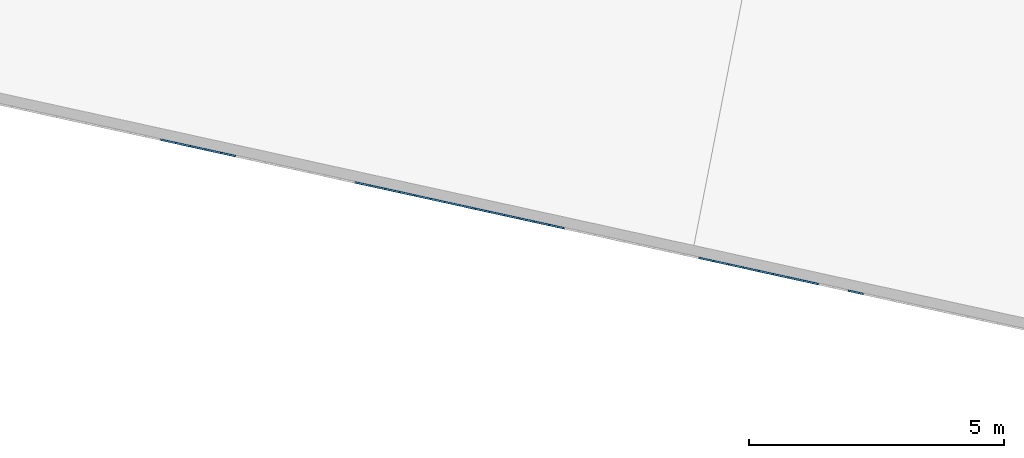
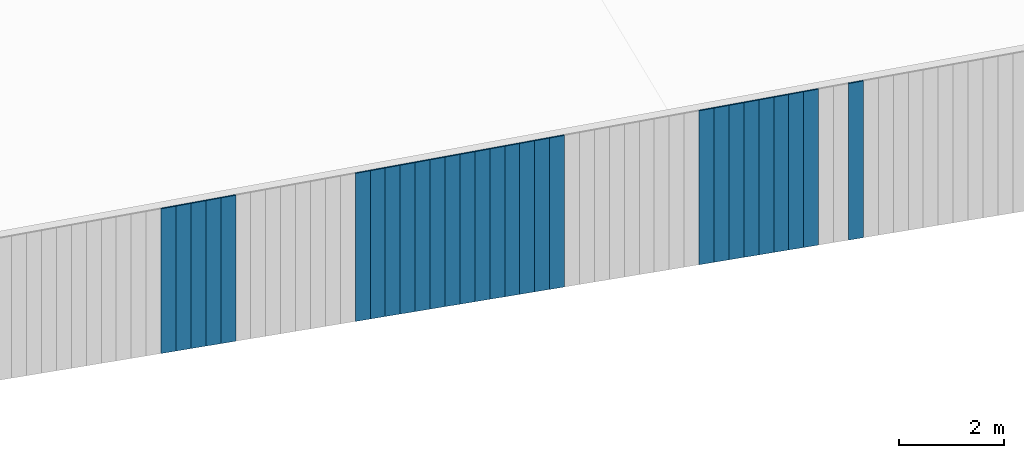
# One storey, part 3 of 18: 28 plates, 1 element without a shape of its own.
"""IFC2X3 building model written with IfcOpenShell, lengths in centimetres."""

from ifc_helpers import new_model, entity, si_unit, converted_unit, derived_unit, direction, frame, origin, place, context, subcontext, project, spatial, polyline, outline, extrude, source, transform, mapped, material, layer, layer_set, layer_usage, type_object, type_shapes, element, aggregate, save


model = new_model("IFC2X3")

# Units and contexts
model_context = context("Model", 3, precision=0.001, world=origin(), true_north=direction((6.12303176911189e-17, 1.0)))
body_context = subcontext(model_context, "Body", "Model", "MODEL_VIEW")
ifc_project = project(units=[si_unit("LENGTHUNIT", "METRE", prefix="CENTI"), si_unit("AREAUNIT", "SQUARE_METRE"), si_unit("VOLUMEUNIT", "CUBIC_METRE"), converted_unit("PLANEANGLEUNIT", "DEGREE", entity("IfcRatioMeasure", 0.0174532925199433), si_unit("PLANEANGLEUNIT", "RADIAN"), dimensions=[0, 0, 0, 0, 0, 0, 0]), si_unit("MASSUNIT", "GRAM", prefix="KILO"), derived_unit("MASSDENSITYUNIT", [(si_unit("MASSUNIT", "GRAM", prefix="KILO"), 1), (si_unit("LENGTHUNIT", "METRE"), -3)]), si_unit("TIMEUNIT", "SECOND"), si_unit("FREQUENCYUNIT", "HERTZ"), si_unit("THERMODYNAMICTEMPERATUREUNIT", "DEGREE_CELSIUS"), derived_unit("THERMALTRANSMITTANCEUNIT", [(si_unit("MASSUNIT", "GRAM", prefix="KILO"), 1), (si_unit("THERMODYNAMICTEMPERATUREUNIT", "KELVIN"), -1), (si_unit("TIMEUNIT", "SECOND"), -3)]), derived_unit("VOLUMETRICFLOWRATEUNIT", [(si_unit("LENGTHUNIT", "METRE"), 3), (si_unit("TIMEUNIT", "SECOND"), -1)]), si_unit("ELECTRICCURRENTUNIT", "AMPERE"), si_unit("ELECTRICVOLTAGEUNIT", "VOLT"), si_unit("POWERUNIT", "WATT"), si_unit("FORCEUNIT", "NEWTON", prefix="KILO"), si_unit("ILLUMINANCEUNIT", "LUX"), si_unit("LUMINOUSFLUXUNIT", "LUMEN"), si_unit("LUMINOUSINTENSITYUNIT", "CANDELA"), derived_unit("USERDEFINED", [(si_unit("MASSUNIT", "GRAM", prefix="KILO"), -1), (si_unit("LENGTHUNIT", "METRE"), -2), (si_unit("TIMEUNIT", "SECOND"), 3), (si_unit("LUMINOUSFLUXUNIT", "LUMEN"), 1)]), derived_unit("LINEARVELOCITYUNIT", [(si_unit("LENGTHUNIT", "METRE"), 1), (si_unit("TIMEUNIT", "SECOND"), -1)]), si_unit("PRESSUREUNIT", "PASCAL"), derived_unit("USERDEFINED", [(si_unit("LENGTHUNIT", "METRE"), -2), (si_unit("MASSUNIT", "GRAM", prefix="KILO"), 1), (si_unit("TIMEUNIT", "SECOND"), -2)])], contexts=[model_context])

# Site, building, storey
site_placement = place(None, origin())
site = spatial("IfcSite", under=ifc_project, at=site_placement, CompositionType="ELEMENT")
building_placement = place(site_placement, origin())
building = spatial("IfcBuilding", under=site, at=building_placement, CompositionType="ELEMENT")
storey_placement = place(building_placement, frame((0.0, 0.0, 1422.0)))
storey = spatial("IfcBuildingStorey", under=building, at=storey_placement, CompositionType="ELEMENT", Elevation=1422.0)

# Curtain wall, plates
curtain_wall_type = type_object("IfcCurtainWallType", PredefinedType="NOTDEFINED")
curtain_wall_placement = place(storey_placement, frame((0.0, 0.0, -1422.0)))
curtain_wall = element("IfcCurtainWall", 1, at=curtain_wall_placement, inside=storey, type_object=curtain_wall_type)
ifc_material = material()
ifc_layer = layer(ifc_material, 3.0)
ifc_layer_set = layer_set([ifc_layer])
ifc_layer_usage_1 = layer_usage(ifc_layer_set, "AXIS3", "POSITIVE", 0.0492125984251968)
plate_type_1 = type_object("IfcPlateType", Name="Panneau plein ST", PredefinedType="CURTAIN_PANEL", material=ifc_layer_set)
shared_shape_1 = source(origin(), body_context, "Body", "SweptSolid", [
    extrude(outline(polyline([(-183.212415380879, -15.0), (182.912850252961, -15.0), (182.912850252961, 15.0), (-182.613285125043, 15.0), (-183.212415380879, -15.0)])), frame((0.0, 0.0, 183.212415380879), z_axis=(0.0, 1.0, 0.0), x_axis=(0.0, 0.0, 1.0)), (0.0, 0.0, 1.0), 3.0),
])
type_shapes(plate_type_1, [shared_shape_1])
plate_1_placement = place(curtain_wall_placement, frame((6807.38308458156, 477.823414082105, 1055.87473436616), z_axis=(0.0, 0.0, 1.0), x_axis=(-0.976731958442773, 0.214463706385357, 0.0)))
plate_1 = element("IfcPlate", 2, at=plate_1_placement, type_object=plate_type_1, material=ifc_layer_usage_1, ObjectType="Panneau plein ST", context=body_context, shape_type="MappedRepresentation", body=[
    mapped(shared_shape_1, transform((0.0, 0.0, 0.0), scale=1.0)),
])
ifc_layer_usage_2 = layer_usage(ifc_layer_set, "AXIS3", "POSITIVE", 0.0492125984251968)
plate_type_2 = type_object("IfcPlateType", Name="Panneau plein ST", PredefinedType="CURTAIN_PANEL", material=ifc_layer_set)
shared_shape_2 = source(origin(), body_context, "Body", "SweptSolid", [
    extrude(outline(polyline([(-182.313719997125, -15.0), (182.014154869207, -15.0), (182.014154869207, 15.0), (-181.714589741289, 15.0), (-182.313719997125, -15.0)])), frame((0.0, 0.0, 182.313719997125), z_axis=(0.0, 1.0, 0.0), x_axis=(0.0, 0.0, 1.0)), (0.0, 0.0, 1.0), 3.0),
])
type_shapes(plate_type_2, [shared_shape_2])
plate_2_placement = place(curtain_wall_placement, frame((6719.47720832171, 497.125147656787, 1057.67212513367), z_axis=(0.0, 0.0, 1.0), x_axis=(-0.976731958442773, 0.214463706385357, 0.0)))
plate_2 = element("IfcPlate", 3, at=plate_2_placement, type_object=plate_type_2, material=ifc_layer_usage_2, ObjectType="Panneau plein ST", context=body_context, shape_type="MappedRepresentation", body=[
    mapped(shared_shape_2, transform((0.0, 0.0, 0.0), scale=1.0)),
])
ifc_layer_usage_3 = layer_usage(ifc_layer_set, "AXIS3", "POSITIVE", 0.0492125984251968)
plate_type_3 = type_object("IfcPlateType", Name="Panneau plein ST", PredefinedType="CURTAIN_PANEL", material=ifc_layer_set)
shared_shape_3 = source(origin(), body_context, "Body", "SweptSolid", [
    extrude(outline(polyline([(-182.014154869207, -15.0), (181.714589741289, -15.0), (181.714589741289, 15.0), (-181.415024613371, 15.0), (-182.014154869207, -15.0)])), frame((0.0, 0.0, 182.014154869207), z_axis=(0.0, 1.0, 0.0), x_axis=(0.0, 0.0, 1.0)), (0.0, 0.0, 1.0), 3.0),
])
type_shapes(plate_type_3, [shared_shape_3])
plate_3_placement = place(curtain_wall_placement, frame((6690.17524956843, 503.559058848348, 1058.2712553895), z_axis=(0.0, 0.0, 1.0), x_axis=(-0.976731958442773, 0.214463706385357, 0.0)))
plate_3 = element("IfcPlate", 4, at=plate_3_placement, type_object=plate_type_3, material=ifc_layer_usage_3, ObjectType="Panneau plein ST", context=body_context, shape_type="MappedRepresentation", body=[
    mapped(shared_shape_3, transform((0.0, 0.0, 0.0), scale=1.0)),
])
ifc_layer_usage_4 = layer_usage(ifc_layer_set, "AXIS3", "POSITIVE", 0.0492125984251968)
plate_type_4 = type_object("IfcPlateType", Name="Panneau plein ST", PredefinedType="CURTAIN_PANEL", material=ifc_layer_set)
shared_shape_4 = source(origin(), body_context, "Body", "SweptSolid", [
    extrude(outline(polyline([(-181.714589741289, -15.0), (181.415024613371, -15.0), (181.415024613371, 15.0), (-181.115459485453, 15.0), (-181.714589741289, -15.0)])), frame((0.0, 0.0, 181.714589741289), z_axis=(0.0, 1.0, 0.0), x_axis=(0.0, 0.0, 1.0)), (0.0, 0.0, 1.0), 3.0),
])
type_shapes(plate_type_4, [shared_shape_4])
plate_4_placement = place(curtain_wall_placement, frame((6660.87329081514, 509.992970039909, 1058.87038564534), z_axis=(0.0, 0.0, 1.0), x_axis=(-0.976731958442773, 0.214463706385357, 0.0)))
plate_4 = element("IfcPlate", 5, at=plate_4_placement, type_object=plate_type_4, material=ifc_layer_usage_4, ObjectType="Panneau plein ST", context=body_context, shape_type="MappedRepresentation", body=[
    mapped(shared_shape_4, transform((0.0, 0.0, 0.0), scale=1.0)),
])
ifc_layer_usage_5 = layer_usage(ifc_layer_set, "AXIS3", "POSITIVE", 0.0492125984251968)
plate_type_5 = type_object("IfcPlateType", Name="Panneau plein ST", PredefinedType="CURTAIN_PANEL", material=ifc_layer_set)
shared_shape_5 = source(origin(), body_context, "Body", "SweptSolid", [
    extrude(outline(polyline([(-181.415024613371, -15.0), (181.115459485453, -15.0), (181.115459485453, 15.0), (-180.815894357535, 15.0), (-181.415024613371, -15.0)])), frame((0.0, 0.0, 181.415024613371), z_axis=(0.0, 1.0, 0.0), x_axis=(0.0, 0.0, 1.0)), (0.0, 0.0, 1.0), 3.0),
])
type_shapes(plate_type_5, [shared_shape_5])
plate_5_placement = place(curtain_wall_placement, frame((6631.57133206186, 516.42688123147, 1059.46951590118), z_axis=(0.0, 0.0, 1.0), x_axis=(-0.976731958442773, 0.214463706385357, 0.0)))
plate_5 = element("IfcPlate", 6, at=plate_5_placement, type_object=plate_type_5, material=ifc_layer_usage_5, ObjectType="Panneau plein ST", context=body_context, shape_type="MappedRepresentation", body=[
    mapped(shared_shape_5, transform((0.0, 0.0, 0.0), scale=1.0)),
])
ifc_layer_usage_6 = layer_usage(ifc_layer_set, "AXIS3", "POSITIVE", 0.0492125984251968)
plate_type_6 = type_object("IfcPlateType", Name="Panneau plein ST", PredefinedType="CURTAIN_PANEL", material=ifc_layer_set)
shared_shape_6 = source(origin(), body_context, "Body", "SweptSolid", [
    extrude(outline(polyline([(-181.115459485453, -15.0), (180.815894357535, -15.0), (180.815894357535, 15.0), (-180.516329229617, 15.0), (-181.115459485453, -15.0)])), frame((0.0, 0.0, 181.115459485453), z_axis=(0.0, 1.0, 0.0), x_axis=(0.0, 0.0, 1.0)), (0.0, 0.0, 1.0), 3.0),
])
type_shapes(plate_type_6, [shared_shape_6])
plate_6_placement = place(curtain_wall_placement, frame((6602.26937330857, 522.86079242303, 1060.06864615701), z_axis=(0.0, 0.0, 1.0), x_axis=(-0.976731958442773, 0.214463706385357, 0.0)))
plate_6 = element("IfcPlate", 7, at=plate_6_placement, type_object=plate_type_6, material=ifc_layer_usage_6, ObjectType="Panneau plein ST", context=body_context, shape_type="MappedRepresentation", body=[
    mapped(shared_shape_6, transform((0.0, 0.0, 0.0), scale=1.0)),
])
ifc_layer_usage_7 = layer_usage(ifc_layer_set, "AXIS3", "POSITIVE", 0.0492125984251968)
plate_type_7 = type_object("IfcPlateType", Name="Panneau plein ST", PredefinedType="CURTAIN_PANEL", material=ifc_layer_set)
shared_shape_7 = source(origin(), body_context, "Body", "SweptSolid", [
    extrude(outline(polyline([(-180.815894357535, -15.0), (180.516329229617, -15.0), (180.516329229617, 15.0), (-180.216764101699, 15.0), (-180.815894357535, -15.0)])), frame((0.0, 0.0, 180.815894357535), z_axis=(0.0, 1.0, 0.0), x_axis=(0.0, 0.0, 1.0)), (0.0, 0.0, 1.0), 3.0),
])
type_shapes(plate_type_7, [shared_shape_7])
plate_7_placement = place(curtain_wall_placement, frame((6572.96741455529, 529.294703614591, 1060.66777641285), z_axis=(0.0, 0.0, 1.0), x_axis=(-0.976731958442773, 0.214463706385357, 0.0)))
plate_7 = element("IfcPlate", 8, at=plate_7_placement, type_object=plate_type_7, material=ifc_layer_usage_7, ObjectType="Panneau plein ST", context=body_context, shape_type="MappedRepresentation", body=[
    mapped(shared_shape_7, transform((0.0, 0.0, 0.0), scale=1.0)),
])
ifc_layer_usage_8 = layer_usage(ifc_layer_set, "AXIS3", "POSITIVE", 0.0492125984251968)
plate_type_8 = type_object("IfcPlateType", Name="Panneau plein ST", PredefinedType="CURTAIN_PANEL", material=ifc_layer_set)
shared_shape_8 = source(origin(), body_context, "Body", "SweptSolid", [
    extrude(outline(polyline([(-180.516329229617, -15.0), (180.216764101699, -15.0), (180.216764101699, 15.0), (-179.917198973781, 15.0), (-180.516329229617, -15.0)])), frame((0.0, 0.0, 180.516329229617), z_axis=(0.0, 1.0, 0.0), x_axis=(0.0, 0.0, 1.0)), (0.0, 0.0, 1.0), 3.0),
])
type_shapes(plate_type_8, [shared_shape_8])
plate_8_placement = place(curtain_wall_placement, frame((6543.66545580201, 535.728614806151, 1061.26690666868), z_axis=(0.0, 0.0, 1.0), x_axis=(-0.976731958442773, 0.214463706385357, 0.0)))
plate_8 = element("IfcPlate", 9, at=plate_8_placement, type_object=plate_type_8, material=ifc_layer_usage_8, ObjectType="Panneau plein ST", context=body_context, shape_type="MappedRepresentation", body=[
    mapped(shared_shape_8, transform((0.0, 0.0, 0.0), scale=1.0)),
])
ifc_layer_usage_9 = layer_usage(ifc_layer_set, "AXIS3", "POSITIVE", 0.0492125984251968)
plate_type_9 = type_object("IfcPlateType", Name="Panneau plein ST", PredefinedType="CURTAIN_PANEL", material=ifc_layer_set)
shared_shape_9 = source(origin(), body_context, "Body", "SweptSolid", [
    extrude(outline(polyline([(-180.216764101699, -15.0), (179.917198973781, -15.0), (179.917198973781, 15.0), (-179.617633845863, 15.0), (-180.216764101699, -15.0)])), frame((0.0, 0.0, 180.216764101699), z_axis=(0.0, 1.0, 0.0), x_axis=(0.0, 0.0, 1.0)), (0.0, 0.0, 1.0), 3.0),
])
type_shapes(plate_type_9, [shared_shape_9])
plate_9_placement = place(curtain_wall_placement, frame((6514.36349704872, 542.162525997712, 1061.86603692452), z_axis=(0.0, 0.0, 1.0), x_axis=(-0.976731958442773, 0.214463706385357, 0.0)))
plate_9 = element("IfcPlate", 10, at=plate_9_placement, type_object=plate_type_9, material=ifc_layer_usage_9, ObjectType="Panneau plein ST", context=body_context, shape_type="MappedRepresentation", body=[
    mapped(shared_shape_9, transform((0.0, 0.0, 0.0), scale=1.0)),
])
ifc_layer_usage_10 = layer_usage(ifc_layer_set, "AXIS3", "POSITIVE", 0.0492125984251968)
plate_type_10 = type_object("IfcPlateType", Name="Panneau plein ST", PredefinedType="CURTAIN_PANEL", material=ifc_layer_set)
shared_shape_10 = source(origin(), body_context, "Body", "SweptSolid", [
    extrude(outline(polyline([(-177.221112822519, -15.0), (176.921547694601, -15.0), (176.921547694601, 15.0), (-176.621982566683, 15.0), (-177.221112822519, -15.0)])), frame((0.0, 0.0, 177.221112822519), z_axis=(0.0, 1.0, 0.0), x_axis=(0.0, 0.0, 1.0)), (0.0, 0.0, 1.0), 3.0),
])
type_shapes(plate_type_10, [shared_shape_10])
plate_10_placement = place(curtain_wall_placement, frame((6221.34390951589, 606.50163791332, 1067.85733948288), z_axis=(0.0, 0.0, 1.0), x_axis=(-0.976731958442773, 0.214463706385357, 0.0)))
plate_10 = element("IfcPlate", 11, at=plate_10_placement, type_object=plate_type_10, material=ifc_layer_usage_10, ObjectType="Panneau plein ST", context=body_context, shape_type="MappedRepresentation", body=[
    mapped(shared_shape_10, transform((0.0, 0.0, 0.0), scale=1.0)),
])
ifc_layer_usage_11 = layer_usage(ifc_layer_set, "AXIS3", "POSITIVE", 0.0492125984251968)
plate_type_11 = type_object("IfcPlateType", Name="Panneau plein ST", PredefinedType="CURTAIN_PANEL", material=ifc_layer_set)
shared_shape_11 = source(origin(), body_context, "Body", "SweptSolid", [
    extrude(outline(polyline([(-176.921547694601, -15.0), (176.621982566683, -15.0), (176.621982566683, 15.0), (-176.322417438765, 15.0), (-176.921547694601, -15.0)])), frame((0.0, 0.0, 176.921547694601), z_axis=(0.0, 1.0, 0.0), x_axis=(0.0, 0.0, 1.0)), (0.0, 0.0, 1.0), 3.0),
])
type_shapes(plate_type_11, [shared_shape_11])
plate_11_placement = place(curtain_wall_placement, frame((6192.04195076261, 612.93554910488, 1068.45646973872), z_axis=(0.0, 0.0, 1.0), x_axis=(-0.976731958442773, 0.214463706385357, 0.0)))
plate_11 = element("IfcPlate", 12, at=plate_11_placement, type_object=plate_type_11, material=ifc_layer_usage_11, ObjectType="Panneau plein ST", context=body_context, shape_type="MappedRepresentation", body=[
    mapped(shared_shape_11, transform((0.0, 0.0, 0.0), scale=1.0)),
])
ifc_layer_usage_12 = layer_usage(ifc_layer_set, "AXIS3", "POSITIVE", 0.0492125984251968)
plate_type_12 = type_object("IfcPlateType", Name="Panneau plein ST", PredefinedType="CURTAIN_PANEL", material=ifc_layer_set)
shared_shape_12 = source(origin(), body_context, "Body", "SweptSolid", [
    extrude(outline(polyline([(-176.621982566683, -15.0), (176.322417438765, -15.0), (176.322417438765, 15.0), (-176.022852310847, 15.0), (-176.621982566683, -15.0)])), frame((0.0, 0.0, 176.621982566683), z_axis=(0.0, 1.0, 0.0), x_axis=(0.0, 0.0, 1.0)), (0.0, 0.0, 1.0), 3.0),
])
type_shapes(plate_type_12, [shared_shape_12])
plate_12_placement = place(curtain_wall_placement, frame((6162.73999200932, 619.369460296441, 1069.05559999455), z_axis=(0.0, 0.0, 1.0), x_axis=(-0.976731958442773, 0.214463706385357, 0.0)))
plate_12 = element("IfcPlate", 13, at=plate_12_placement, type_object=plate_type_12, material=ifc_layer_usage_12, ObjectType="Panneau plein ST", context=body_context, shape_type="MappedRepresentation", body=[
    mapped(shared_shape_12, transform((0.0, 0.0, 0.0), scale=1.0)),
])
ifc_layer_usage_13 = layer_usage(ifc_layer_set, "AXIS3", "POSITIVE", 0.0492125984251968)
plate_type_13 = type_object("IfcPlateType", Name="Panneau plein ST", PredefinedType="CURTAIN_PANEL", material=ifc_layer_set)
shared_shape_13 = source(origin(), body_context, "Body", "SweptSolid", [
    extrude(outline(polyline([(-176.322417438765, -15.0), (176.022852310847, -15.0), (176.022852310847, 15.0), (-175.723287182929, 15.0), (-176.322417438765, -15.0)])), frame((0.0, 0.0, 176.322417438765), z_axis=(0.0, 1.0, 0.0), x_axis=(0.0, 0.0, 1.0)), (0.0, 0.0, 1.0), 3.0),
])
type_shapes(plate_type_13, [shared_shape_13])
plate_13_placement = place(curtain_wall_placement, frame((6133.43803325604, 625.803371488002, 1069.65473025039), z_axis=(0.0, 0.0, 1.0), x_axis=(-0.976731958442773, 0.214463706385357, 0.0)))
plate_13 = element("IfcPlate", 14, at=plate_13_placement, type_object=plate_type_13, material=ifc_layer_usage_13, ObjectType="Panneau plein ST", context=body_context, shape_type="MappedRepresentation", body=[
    mapped(shared_shape_13, transform((0.0, 0.0, 0.0), scale=1.0)),
])
ifc_layer_usage_14 = layer_usage(ifc_layer_set, "AXIS3", "POSITIVE", 0.0492125984251968)
plate_type_14 = type_object("IfcPlateType", Name="Panneau plein ST", PredefinedType="CURTAIN_PANEL", material=ifc_layer_set)
shared_shape_14 = source(origin(), body_context, "Body", "SweptSolid", [
    extrude(outline(polyline([(-176.022852310847, -15.0), (175.723287182929, -15.0), (175.723287182929, 15.0), (-175.423722055011, 15.0), (-176.022852310847, -15.0)])), frame((0.0, 0.0, 176.022852310847), z_axis=(0.0, 1.0, 0.0), x_axis=(0.0, 0.0, 1.0)), (0.0, 0.0, 1.0), 3.0),
])
type_shapes(plate_type_14, [shared_shape_14])
plate_14_placement = place(curtain_wall_placement, frame((6104.13607450276, 632.237282679563, 1070.25386050622), z_axis=(0.0, 0.0, 1.0), x_axis=(-0.976731958442773, 0.214463706385357, 0.0)))
plate_14 = element("IfcPlate", 15, at=plate_14_placement, type_object=plate_type_14, material=ifc_layer_usage_14, ObjectType="Panneau plein ST", context=body_context, shape_type="MappedRepresentation", body=[
    mapped(shared_shape_14, transform((0.0, 0.0, 0.0), scale=1.0)),
])
ifc_layer_usage_15 = layer_usage(ifc_layer_set, "AXIS3", "POSITIVE", 0.0492125984251968)
plate_type_15 = type_object("IfcPlateType", Name="Panneau plein ST", PredefinedType="CURTAIN_PANEL", material=ifc_layer_set)
shared_shape_15 = source(origin(), body_context, "Body", "SweptSolid", [
    extrude(outline(polyline([(-175.723287182929, -15.0), (175.423722055011, -15.0), (175.423722055011, 15.0), (-175.124156927093, 15.0), (-175.723287182929, -15.0)])), frame((0.0, 0.0, 175.723287182929), z_axis=(0.0, 1.0, 0.0), x_axis=(0.0, 0.0, 1.0)), (0.0, 0.0, 1.0), 3.0),
])
type_shapes(plate_type_15, [shared_shape_15])
plate_15_placement = place(curtain_wall_placement, frame((6074.83411574947, 638.671193871123, 1070.85299076206), z_axis=(0.0, 0.0, 1.0), x_axis=(-0.976731958442773, 0.214463706385357, 0.0)))
plate_15 = element("IfcPlate", 16, at=plate_15_placement, type_object=plate_type_15, material=ifc_layer_usage_15, ObjectType="Panneau plein ST", context=body_context, shape_type="MappedRepresentation", body=[
    mapped(shared_shape_15, transform((0.0, 0.0, 0.0), scale=1.0)),
])
ifc_layer_usage_16 = layer_usage(ifc_layer_set, "AXIS3", "POSITIVE", 0.0492125984251968)
plate_type_16 = type_object("IfcPlateType", Name="Panneau plein ST", PredefinedType="CURTAIN_PANEL", material=ifc_layer_set)
shared_shape_16 = source(origin(), body_context, "Body", "SweptSolid", [
    extrude(outline(polyline([(-175.423722055011, -15.0), (175.124156927093, -15.0), (175.124156927093, 15.0), (-174.824591799175, 15.0), (-175.423722055011, -15.0)])), frame((0.0, 0.0, 175.423722055011), z_axis=(0.0, 1.0, 0.0), x_axis=(0.0, 0.0, 1.0)), (0.0, 0.0, 1.0), 3.0),
])
type_shapes(plate_type_16, [shared_shape_16])
plate_16_placement = place(curtain_wall_placement, frame((6045.53215699619, 645.105105062684, 1071.4521210179), z_axis=(0.0, 0.0, 1.0), x_axis=(-0.976731958442773, 0.214463706385357, 0.0)))
plate_16 = element("IfcPlate", 17, at=plate_16_placement, type_object=plate_type_16, material=ifc_layer_usage_16, ObjectType="Panneau plein ST", context=body_context, shape_type="MappedRepresentation", body=[
    mapped(shared_shape_16, transform((0.0, 0.0, 0.0), scale=1.0)),
])
ifc_layer_usage_17 = layer_usage(ifc_layer_set, "AXIS3", "POSITIVE", 0.0492125984251968)
plate_type_17 = type_object("IfcPlateType", Name="Panneau plein ST", PredefinedType="CURTAIN_PANEL", material=ifc_layer_set)
shared_shape_17 = source(origin(), body_context, "Body", "SweptSolid", [
    extrude(outline(polyline([(-175.124156927093, -15.0), (174.824591799175, -15.0), (174.824591799175, 15.0), (-174.525026671257, 15.0), (-175.124156927093, -15.0)])), frame((0.0, 0.0, 175.124156927093), z_axis=(0.0, 1.0, 0.0), x_axis=(0.0, 0.0, 1.0)), (0.0, 0.0, 1.0), 3.0),
])
type_shapes(plate_type_17, [shared_shape_17])
plate_17_placement = place(curtain_wall_placement, frame((6016.23019824291, 651.539016254245, 1072.05125127373), z_axis=(0.0, 0.0, 1.0), x_axis=(-0.976731958442773, 0.214463706385357, 0.0)))
plate_17 = element("IfcPlate", 18, at=plate_17_placement, type_object=plate_type_17, material=ifc_layer_usage_17, ObjectType="Panneau plein ST", context=body_context, shape_type="MappedRepresentation", body=[
    mapped(shared_shape_17, transform((0.0, 0.0, 0.0), scale=1.0)),
])
ifc_layer_usage_18 = layer_usage(ifc_layer_set, "AXIS3", "POSITIVE", 0.0492125984251968)
plate_type_18 = type_object("IfcPlateType", Name="Panneau plein ST", PredefinedType="CURTAIN_PANEL", material=ifc_layer_set)
shared_shape_18 = source(origin(), body_context, "Body", "SweptSolid", [
    extrude(outline(polyline([(-174.824591799175, -15.0), (174.525026671257, -15.0), (174.525026671257, 15.0), (-174.225461543339, 15.0), (-174.824591799175, -15.0)])), frame((0.0, 0.0, 174.824591799175), z_axis=(0.0, 1.0, 0.0), x_axis=(0.0, 0.0, 1.0)), (0.0, 0.0, 1.0), 3.0),
])
type_shapes(plate_type_18, [shared_shape_18])
plate_18_placement = place(curtain_wall_placement, frame((5986.92823948962, 657.972927445805, 1072.65038152957), z_axis=(0.0, 0.0, 1.0), x_axis=(-0.976731958442773, 0.214463706385357, 0.0)))
plate_18 = element("IfcPlate", 19, at=plate_18_placement, type_object=plate_type_18, material=ifc_layer_usage_18, ObjectType="Panneau plein ST", context=body_context, shape_type="MappedRepresentation", body=[
    mapped(shared_shape_18, transform((0.0, 0.0, 0.0), scale=1.0)),
])
ifc_layer_usage_19 = layer_usage(ifc_layer_set, "AXIS3", "POSITIVE", 0.0492125984251968)
plate_type_19 = type_object("IfcPlateType", Name="Panneau plein ST", PredefinedType="CURTAIN_PANEL", material=ifc_layer_set)
shared_shape_19 = source(origin(), body_context, "Body", "SweptSolid", [
    extrude(outline(polyline([(-174.525026671257, -15.0), (174.225461543339, -15.0), (174.225461543339, 15.0), (-173.925896415421, 15.0), (-174.525026671257, -15.0)])), frame((0.0, 0.0, 174.525026671257), z_axis=(0.0, 1.0, 0.0), x_axis=(0.0, 0.0, 1.0)), (0.0, 0.0, 1.0), 3.0),
])
type_shapes(plate_type_19, [shared_shape_19])
plate_19_placement = place(curtain_wall_placement, frame((5957.62628073634, 664.406838637366, 1073.2495117854), z_axis=(0.0, 0.0, 1.0), x_axis=(-0.976731958442773, 0.214463706385357, 0.0)))
plate_19 = element("IfcPlate", 20, at=plate_19_placement, type_object=plate_type_19, material=ifc_layer_usage_19, ObjectType="Panneau plein ST", context=body_context, shape_type="MappedRepresentation", body=[
    mapped(shared_shape_19, transform((0.0, 0.0, 0.0), scale=1.0)),
])
ifc_layer_usage_20 = layer_usage(ifc_layer_set, "AXIS3", "POSITIVE", 0.0492125984251968)
plate_type_20 = type_object("IfcPlateType", Name="Panneau plein ST", PredefinedType="CURTAIN_PANEL", material=ifc_layer_set)
shared_shape_20 = source(origin(), body_context, "Body", "SweptSolid", [
    extrude(outline(polyline([(-174.225461543339, -15.0), (173.925896415421, -15.0), (173.925896415421, 15.0), (-173.626331287503, 15.0), (-174.225461543339, -15.0)])), frame((0.0, 0.0, 174.225461543339), z_axis=(0.0, 1.0, 0.0), x_axis=(0.0, 0.0, 1.0)), (0.0, 0.0, 1.0), 3.0),
])
type_shapes(plate_type_20, [shared_shape_20])
plate_20_placement = place(curtain_wall_placement, frame((5928.32432198306, 670.840749828927, 1073.84864204124), z_axis=(0.0, 0.0, 1.0), x_axis=(-0.976731958442773, 0.214463706385357, 0.0)))
plate_20 = element("IfcPlate", 21, at=plate_20_placement, type_object=plate_type_20, material=ifc_layer_usage_20, ObjectType="Panneau plein ST", context=body_context, shape_type="MappedRepresentation", body=[
    mapped(shared_shape_20, transform((0.0, 0.0, 0.0), scale=1.0)),
])
ifc_layer_usage_21 = layer_usage(ifc_layer_set, "AXIS3", "POSITIVE", 0.0492125984251968)
plate_type_21 = type_object("IfcPlateType", Name="Panneau plein ST", PredefinedType="CURTAIN_PANEL", material=ifc_layer_set)
shared_shape_21 = source(origin(), body_context, "Body", "SweptSolid", [
    extrude(outline(polyline([(-173.92589641542, -15.0), (173.626331287503, -15.0), (173.626331287503, 15.0), (-173.326766159585, 15.0), (-173.92589641542, -15.0)])), frame((0.0, 0.0, 173.925896415421), z_axis=(0.0, 1.0, 0.0), x_axis=(0.0, 0.0, 1.0)), (0.0, 0.0, 1.0), 3.0),
])
type_shapes(plate_type_21, [shared_shape_21])
plate_21_placement = place(curtain_wall_placement, frame((5899.02236322977, 677.274661020488, 1074.44777229708), z_axis=(0.0, 0.0, 1.0), x_axis=(-0.976731958442773, 0.214463706385357, 0.0)))
plate_21 = element("IfcPlate", 22, at=plate_21_placement, type_object=plate_type_21, material=ifc_layer_usage_21, ObjectType="Panneau plein ST", context=body_context, shape_type="MappedRepresentation", body=[
    mapped(shared_shape_21, transform((0.0, 0.0, 0.0), scale=1.0)),
])
ifc_layer_usage_22 = layer_usage(ifc_layer_set, "AXIS3", "POSITIVE", 0.0492125984251968)
plate_type_22 = type_object("IfcPlateType", Name="Panneau plein ST", PredefinedType="CURTAIN_PANEL", material=ifc_layer_set)
shared_shape_22 = source(origin(), body_context, "Body", "SweptSolid", [
    extrude(outline(polyline([(-173.626331287503, -15.0), (173.326766159585, -15.0), (173.326766159585, 15.0), (-173.027201031667, 15.0), (-173.626331287503, -15.0)])), frame((0.0, 0.0, 173.626331287502), z_axis=(0.0, 1.0, 0.0), x_axis=(0.0, 0.0, 1.0)), (0.0, 0.0, 1.0), 3.0),
])
type_shapes(plate_type_22, [shared_shape_22])
plate_22_placement = place(curtain_wall_placement, frame((5869.72040447649, 683.708572212048, 1075.04690255291), z_axis=(0.0, 0.0, 1.0), x_axis=(-0.976731958442773, 0.214463706385357, 0.0)))
plate_22 = element("IfcPlate", 23, at=plate_22_placement, type_object=plate_type_22, material=ifc_layer_usage_22, ObjectType="Panneau plein ST", context=body_context, shape_type="MappedRepresentation", body=[
    mapped(shared_shape_22, transform((0.0, 0.0, 0.0), scale=1.0)),
])
ifc_layer_usage_23 = layer_usage(ifc_layer_set, "AXIS3", "POSITIVE", 0.0492125984251968)
plate_type_23 = type_object("IfcPlateType", Name="Panneau plein ST", PredefinedType="CURTAIN_PANEL", material=ifc_layer_set)
shared_shape_23 = source(origin(), body_context, "Body", "SweptSolid", [
    extrude(outline(polyline([(-173.326766159585, -15.0), (173.027201031667, -15.0), (173.027201031667, 15.0), (-172.727635903749, 15.0), (-173.326766159585, -15.0)])), frame((0.0, 0.0, 173.326766159585), z_axis=(0.0, 1.0, 0.0), x_axis=(0.0, 0.0, 1.0)), (0.0, 0.0, 1.0), 3.0),
])
type_shapes(plate_type_23, [shared_shape_23])
plate_23_placement = place(curtain_wall_placement, frame((5840.41844572321, 690.142483403609, 1075.64603280875), z_axis=(0.0, 0.0, 1.0), x_axis=(-0.976731958442773, 0.214463706385357, 0.0)))
plate_23 = element("IfcPlate", 24, at=plate_23_placement, type_object=plate_type_23, material=ifc_layer_usage_23, ObjectType="Panneau plein ST", context=body_context, shape_type="MappedRepresentation", body=[
    mapped(shared_shape_23, transform((0.0, 0.0, 0.0), scale=1.0)),
])
ifc_layer_usage_24 = layer_usage(ifc_layer_set, "AXIS3", "POSITIVE", 0.0492125984251968)
plate_type_24 = type_object("IfcPlateType", Name="Panneau plein ST", PredefinedType="CURTAIN_PANEL", material=ifc_layer_set)
shared_shape_24 = source(origin(), body_context, "Body", "SweptSolid", [
    extrude(outline(polyline([(-170.630680008322, -15.0), (170.331114880405, -15.0), (170.331114880404, 15.0), (-170.031549752487, 15.0), (-170.630680008322, -15.0)])), frame((0.0, 0.0, 170.630680008323), z_axis=(0.0, 1.0, 0.0), x_axis=(0.0, 0.0, 1.0)), (0.0, 0.0, 1.0), 3.0),
])
type_shapes(plate_type_24, [shared_shape_24])
plate_24_placement = place(curtain_wall_placement, frame((5576.70081694366, 748.047684127656, 1081.03820511127), z_axis=(0.0, 0.0, 1.0), x_axis=(-0.976731958442773, 0.214463706385357, 0.0)))
plate_24 = element("IfcPlate", 25, at=plate_24_placement, type_object=plate_type_24, material=ifc_layer_usage_24, ObjectType="Panneau plein ST", context=body_context, shape_type="MappedRepresentation", body=[
    mapped(shared_shape_24, transform((0.0, 0.0, 0.0), scale=1.0)),
])
ifc_layer_usage_25 = layer_usage(ifc_layer_set, "AXIS3", "POSITIVE", 0.0492125984251968)
plate_type_25 = type_object("IfcPlateType", Name="Panneau plein ST", PredefinedType="CURTAIN_PANEL", material=ifc_layer_set)
shared_shape_25 = source(origin(), body_context, "Body", "SweptSolid", [
    extrude(outline(polyline([(-170.331114880405, -15.0), (170.031549752486, -15.0), (170.031549752487, 15.0), (-169.731984624568, 15.0), (-170.331114880405, -15.0)])), frame((0.0, 0.0, 170.331114880405), z_axis=(0.0, 1.0, 0.0), x_axis=(0.0, 0.0, 1.0)), (0.0, 0.0, 1.0), 3.0),
])
type_shapes(plate_type_25, [shared_shape_25])
plate_25_placement = place(curtain_wall_placement, frame((5547.39885819037, 754.481595319216, 1081.63733536711), z_axis=(0.0, 0.0, 1.0), x_axis=(-0.976731958442773, 0.214463706385357, 0.0)))
plate_25 = element("IfcPlate", 26, at=plate_25_placement, type_object=plate_type_25, material=ifc_layer_usage_25, ObjectType="Panneau plein ST", context=body_context, shape_type="MappedRepresentation", body=[
    mapped(shared_shape_25, transform((0.0, 0.0, 0.0), scale=1.0)),
])
ifc_layer_usage_26 = layer_usage(ifc_layer_set, "AXIS3", "POSITIVE", 0.0492125984251968)
plate_type_26 = type_object("IfcPlateType", Name="Panneau plein ST", PredefinedType="CURTAIN_PANEL", material=ifc_layer_set)
shared_shape_26 = source(origin(), body_context, "Body", "SweptSolid", [
    extrude(outline(polyline([(-170.031549752486, -15.0), (169.731984624568, -15.0), (169.731984624568, 15.0), (-169.43241949665, 15.0), (-170.031549752486, -15.0)])), frame((0.0, 0.0, 170.031549752487), z_axis=(0.0, 1.0, 0.0), x_axis=(0.0, 0.0, 1.0)), (0.0, 0.0, 1.0), 3.0),
])
type_shapes(plate_type_26, [shared_shape_26])
plate_26_placement = place(curtain_wall_placement, frame((5518.09689943709, 760.915506510777, 1082.23646562294), z_axis=(0.0, 0.0, 1.0), x_axis=(-0.976731958442773, 0.214463706385357, 0.0)))
plate_26 = element("IfcPlate", 27, at=plate_26_placement, type_object=plate_type_26, material=ifc_layer_usage_26, ObjectType="Panneau plein ST", context=body_context, shape_type="MappedRepresentation", body=[
    mapped(shared_shape_26, transform((0.0, 0.0, 0.0), scale=1.0)),
])
ifc_layer_usage_27 = layer_usage(ifc_layer_set, "AXIS3", "POSITIVE", 0.0492125984251968)
plate_type_27 = type_object("IfcPlateType", Name="Panneau plein ST", PredefinedType="CURTAIN_PANEL", material=ifc_layer_set)
shared_shape_27 = source(origin(), body_context, "Body", "SweptSolid", [
    extrude(outline(polyline([(-169.731984624568, -15.0), (169.43241949665, -15.0), (169.43241949665, 15.0), (-169.132854368732, 15.0), (-169.731984624568, -15.0)])), frame((0.0, 0.0, 169.731984624568), z_axis=(0.0, 1.0, 0.0), x_axis=(0.0, 0.0, 1.0)), (0.0, 0.0, 1.0), 3.0),
])
type_shapes(plate_type_27, [shared_shape_27])
plate_27_placement = place(curtain_wall_placement, frame((5488.79494068381, 767.349417702338, 1082.83559587878), z_axis=(0.0, 0.0, 1.0), x_axis=(-0.976731958442773, 0.214463706385357, 0.0)))
plate_27 = element("IfcPlate", 28, at=plate_27_placement, type_object=plate_type_27, material=ifc_layer_usage_27, ObjectType="Panneau plein ST", context=body_context, shape_type="MappedRepresentation", body=[
    mapped(shared_shape_27, transform((0.0, 0.0, 0.0), scale=1.0)),
])
ifc_layer_usage_28 = layer_usage(ifc_layer_set, "AXIS3", "POSITIVE", 0.0492125984251968)
plate_type_28 = type_object("IfcPlateType", Name="Panneau plein ST", PredefinedType="CURTAIN_PANEL", material=ifc_layer_set)
shared_shape_28 = source(origin(), body_context, "Body", "SweptSolid", [
    extrude(outline(polyline([(-169.43241949665, -15.0), (169.132854368732, -15.0), (169.132854368732, 15.0), (-168.833289240814, 15.0), (-169.43241949665, -15.0)])), frame((0.0, 0.0, 169.43241949665), z_axis=(0.0, 1.0, 0.0), x_axis=(0.0, 0.0, 1.0)), (0.0, 0.0, 1.0), 3.0),
])
type_shapes(plate_type_28, [shared_shape_28])
plate_28_placement = place(curtain_wall_placement, frame((5459.49298193052, 773.783328893898, 1083.43472613462), z_axis=(0.0, 0.0, 1.0), x_axis=(-0.976731958442773, 0.214463706385357, 0.0)))
plate_28 = element("IfcPlate", 29, at=plate_28_placement, type_object=plate_type_28, material=ifc_layer_usage_28, ObjectType="Panneau plein ST", context=body_context, shape_type="MappedRepresentation", body=[
    mapped(shared_shape_28, transform((0.0, 0.0, 0.0), scale=1.0)),
])
aggregate(curtain_wall, [plate_1, plate_2, plate_3, plate_4, plate_5, plate_6, plate_7, plate_8, plate_9, plate_10, plate_11, plate_12, plate_13, plate_14, plate_15, plate_16, plate_17, plate_18, plate_19, plate_20, plate_21, plate_22, plate_23, plate_24, plate_25, plate_26, plate_27, plate_28])

save(model, "model.ifc")
